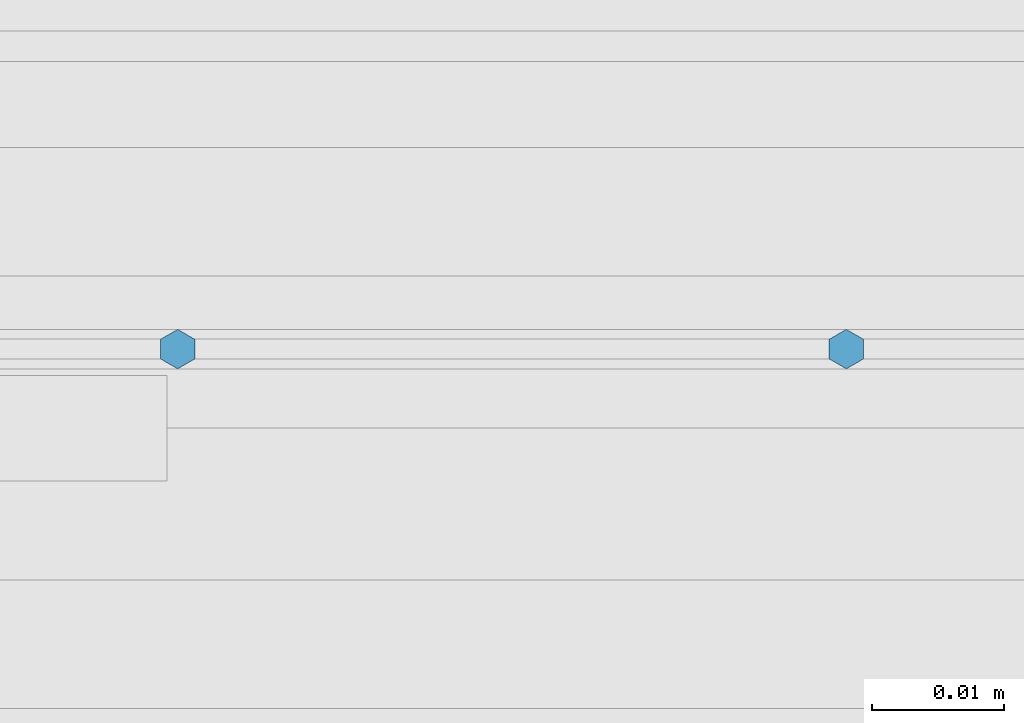
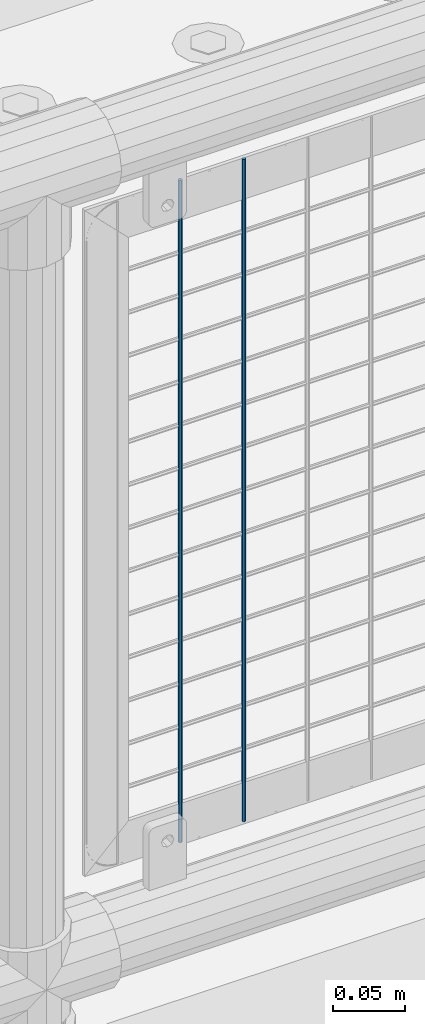
# One storey, part 71 of 242: 2 columns.
"""IFC2X3 building model written with IfcOpenShell, lengths in millimetres."""

from ifc_helpers import new_model, si_unit, frame, origin_with_axes, place, context, subcontext, project, spatial, faceted_brep, material, type_object, element, save


model = new_model("IFC2X3")

# Units and contexts
model_context = context("Model", 3, precision=1e-05, world=origin_with_axes())
body_context = subcontext(model_context, "Body", "Model", "MODEL_VIEW")
ifc_project = project(units=[si_unit("LENGTHUNIT", "METRE", prefix="MILLI"), si_unit("AREAUNIT", "SQUARE_METRE"), si_unit("VOLUMEUNIT", "CUBIC_METRE"), si_unit("MASSUNIT", "GRAM", prefix="KILO"), si_unit("TIMEUNIT", "SECOND"), si_unit("PLANEANGLEUNIT", "RADIAN"), si_unit("SOLIDANGLEUNIT", "STERADIAN"), si_unit("THERMODYNAMICTEMPERATUREUNIT", "DEGREE_CELSIUS"), si_unit("LUMINOUSINTENSITYUNIT", "LUMEN")], contexts=[model_context])

# Site, building, storey
site_placement = place(None, origin_with_axes())
site = spatial("IfcSite", under=ifc_project, at=site_placement, CompositionType="ELEMENT")
building_placement = place(site_placement, origin_with_axes())
building = spatial("IfcBuilding", under=site, at=building_placement, Name="Standard", CompositionType="ELEMENT")
storey_placement = place(building_placement, origin_with_axes())
storey = spatial("IfcBuildingStorey", under=building, at=storey_placement, Name="Undefined", CompositionType="ELEMENT", Elevation=0.0)

# Columns
ifc_material = material(Name="Misc_Undefined")
column_type = type_object("IfcColumnType", Name="D3", PredefinedType="NOTDEFINED")
for number, where, z_axis, x_axis in (
    (1, (-38381.414, -19329.5, 353.02), (-1.0, 0.0, 0.0), (0.0, 0.0, 1.0)),
    (2, (-38432.207, -19329.5, 353.02), (-1.0, 0.0, 0.0), (0.0, 0.0, 1.0)),
):
    element("IfcColumn", number, at=place(storey_placement, frame(where, z_axis=z_axis, x_axis=x_axis)), inside=storey, type_object=column_type, material=ifc_material, ObjectType="D3", context=body_context, shape_type="Brep", body=[
        faceted_brep([(0.0, -1.50000000000364, 0.0), (-3.63797880709171e-12, -0.750000000003638, -1.29903810567669), (560.0, -0.75, -1.29903810567703), (560.0, -1.5, 0.0), (0.0, 0.749999999996362, -1.29903810567669), (560.0, 0.75, -1.29903810567703), (-3.63797880709171e-12, 1.49999999999636, 0.0), (560.0, 1.5, 0.0), (0.0, 0.749999999996362, 1.29903810567669), (560.0, 0.75, 1.29903810567703), (-3.63797880709171e-12, -0.750000000003638, 1.29903810567669), (560.0, -0.75, 1.29903810567703)], [[[0, 1, 2, 3]], [[1, 4, 5, 2]], [[4, 6, 7, 5]], [[6, 8, 9, 7]], [[8, 10, 11, 9]], [[10, 0, 3, 11]], [[5, 7, 9, 11, 3, 2]], [[10, 8, 6, 4, 1, 0]]]),
    ])

save(model, "model.ifc")
